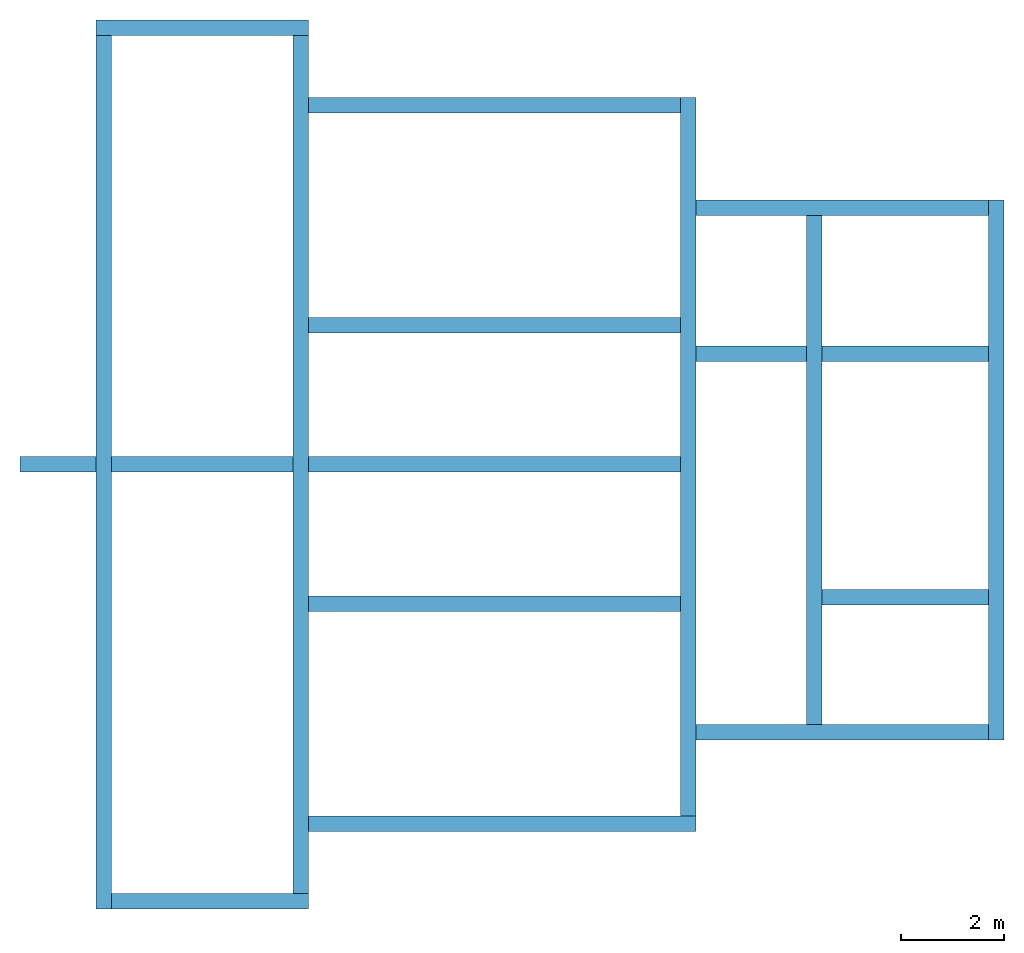
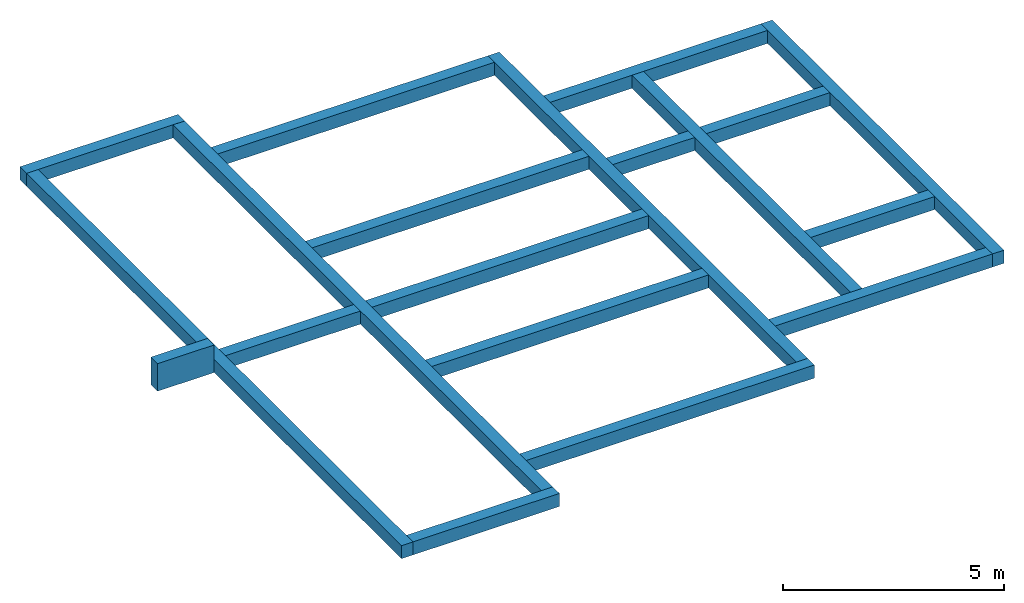
# One storey: 16 walls.
"""IFC2X3 building model written with IfcOpenShell, lengths in millimetres."""

from ifc_helpers import new_model, entity, si_unit, converted_unit, derived_unit, direction, frame, frame_2d, origin, place, context, subcontext, project, spatial, polyline, rectangle, extrude, clip, bounded_halfspace, material, layer, layer_set, layer_usage, type_object, element, save


model = new_model("IFC2X3")

# Units and contexts
model_context = context("Model", 3, precision=0.01, world=origin(), true_north=direction((6.12303176911189e-17, 1.0)))
body_context = subcontext(model_context, "Body", "Model", "MODEL_VIEW")
ifc_project = project(units=[si_unit("LENGTHUNIT", "METRE", prefix="MILLI"), si_unit("AREAUNIT", "SQUARE_METRE"), si_unit("VOLUMEUNIT", "CUBIC_METRE"), converted_unit("PLANEANGLEUNIT", "DEGREE", entity("IfcRatioMeasure", 0.0174532925199433), si_unit("PLANEANGLEUNIT", "RADIAN"), dimensions=[0, 0, 0, 0, 0, 0, 0]), si_unit("MASSUNIT", "GRAM", prefix="KILO"), derived_unit("MASSDENSITYUNIT", [(si_unit("MASSUNIT", "GRAM", prefix="KILO"), 1), (si_unit("LENGTHUNIT", "METRE"), -3)]), si_unit("TIMEUNIT", "SECOND"), si_unit("FREQUENCYUNIT", "HERTZ"), si_unit("THERMODYNAMICTEMPERATUREUNIT", "DEGREE_CELSIUS"), derived_unit("THERMALTRANSMITTANCEUNIT", [(si_unit("MASSUNIT", "GRAM", prefix="KILO"), 1), (si_unit("THERMODYNAMICTEMPERATUREUNIT", "KELVIN"), -1), (si_unit("TIMEUNIT", "SECOND"), -3)]), derived_unit("VOLUMETRICFLOWRATEUNIT", [(si_unit("LENGTHUNIT", "METRE"), 3), (si_unit("TIMEUNIT", "SECOND"), -1)]), si_unit("ELECTRICCURRENTUNIT", "AMPERE"), si_unit("ELECTRICVOLTAGEUNIT", "VOLT"), si_unit("POWERUNIT", "WATT"), si_unit("FORCEUNIT", "NEWTON", prefix="KILO"), si_unit("ILLUMINANCEUNIT", "LUX"), si_unit("LUMINOUSFLUXUNIT", "LUMEN"), si_unit("LUMINOUSINTENSITYUNIT", "CANDELA"), derived_unit("USERDEFINED", [(si_unit("MASSUNIT", "GRAM", prefix="KILO"), -1), (si_unit("LENGTHUNIT", "METRE"), -2), (si_unit("TIMEUNIT", "SECOND"), 3), (si_unit("LUMINOUSFLUXUNIT", "LUMEN"), 1)]), derived_unit("LINEARVELOCITYUNIT", [(si_unit("LENGTHUNIT", "METRE"), 1), (si_unit("TIMEUNIT", "SECOND"), -1)]), si_unit("PRESSUREUNIT", "PASCAL"), derived_unit("USERDEFINED", [(si_unit("LENGTHUNIT", "METRE"), -2), (si_unit("MASSUNIT", "GRAM", prefix="KILO"), 1), (si_unit("TIMEUNIT", "SECOND"), -2)])], contexts=[model_context])

# Site, building, storey
site_placement = place(None, origin())
site = spatial("IfcSite", under=ifc_project, at=site_placement, CompositionType="ELEMENT")
building_placement = place(site_placement, origin())
building = spatial("IfcBuilding", under=site, at=building_placement, CompositionType="ELEMENT")
storey_placement = place(building_placement, frame((0.0, 0.0, -900.0)))
storey = spatial("IfcBuildingStorey", under=building, at=storey_placement, Name="A1 Top of Foundation", CompositionType="ELEMENT", Elevation=-900.0)

# Walls
ifc_material = material(Name="02_C40/50")
ifc_layer = layer(ifc_material, 300.0)
ifc_layer_set = layer_set([ifc_layer], Name="Basic Wall:300mm Beton")
ifc_layer_usage_1 = layer_usage(ifc_layer_set, "AXIS2", "NEGATIVE", 150.0)
wall_type = type_object("IfcWallType", Name="Basic Wall:300mm Beton", PredefinedType="STANDARD", material=ifc_layer_set)
wall_1_placement = place(storey_placement, frame((21293.4900708518, -60361.2395851399, 0.0), z_axis=(0.0, 0.0, 1.0), x_axis=(-1.0, 0.0, 0.0)))
element("IfcWallStandardCase", 1, at=wall_1_placement, inside=storey, type_object=wall_type, material=ifc_layer_usage_1, Name="Basic Wall:300mm Beton", ObjectType="Basic Wall:300mm Beton", context=body_context, shape_type="Clipping", body=[
    clip(extrude(rectangle(XDim=4120.00000000004, YDim=300.000000000001, at=frame_2d((2060.00000000002, 2.70006239588838e-13), x_axis=(-1.0, 0.0))), origin(), (0.0, 0.0, 1.0), 360.0), bounded_halfspace(frame((0.0, -150.0, 360.0), z_axis=(0.0, 0.0, -1.0), x_axis=(-1.0, 0.0, 0.0)), True, frame((0.0, -150.0, 360.0), z_axis=(0.0, 0.0, -1.0), x_axis=(-1.0, 0.0, 0.0)), polyline([(0.0, 0.0), (0.0, 300.0), (-300.0, 300.0), (-3820.0, 300.0), (-4120.0, 300.0), (-4120.0, 0.0), (0.0, 0.0)]))),
])
ifc_layer_usage_2 = layer_usage(ifc_layer_set, "AXIS2", "NEGATIVE", 150.0)
wall_2_placement = place(storey_placement, frame((17323.4900708518, -60511.2395851399, 0.0), z_axis=(0.0, 0.0, 1.0), x_axis=(0.0, -1.0, 0.0)))
element("IfcWallStandardCase", 2, at=wall_2_placement, inside=storey, type_object=wall_type, material=ifc_layer_usage_2, Name="Basic Wall:300mm Beton", ObjectType="Basic Wall:300mm Beton", context=body_context, shape_type="Clipping", body=[
    clip(extrude(rectangle(XDim=16940.0, YDim=300.000000000001, at=frame_2d((8469.99999999999, -4.2632564145606e-14), x_axis=(-1.0, 0.0))), origin(), (0.0, 0.0, 1.0), 360.0), bounded_halfspace(frame((0.0, -150.0, 360.0), z_axis=(0.0, 0.0, -1.0), x_axis=(0.0, 1.0, 0.0)), True, frame((0.0, -150.0, 360.0), z_axis=(0.0, 0.0, -1.0), x_axis=(0.0, 1.0, 0.0)), polyline([(0.0, 0.0), (300.0, 0.0), (300.0, 8170.0), (300.0, 8470.0), (300.0, 16640.0), (300.0, 16940.0), (0.0, 16940.0), (0.0, 0.0)]))),
])
ifc_layer_usage_3 = layer_usage(ifc_layer_set, "AXIS2", "NEGATIVE", 150.0)
wall_3_placement = place(storey_placement, frame((17473.4900708518, -77301.2395851399, 0.0)))
element("IfcWallStandardCase", 3, at=wall_3_placement, inside=storey, type_object=wall_type, material=ifc_layer_usage_3, Name="Basic Wall:300mm Beton", ObjectType="Basic Wall:300mm Beton", context=body_context, shape_type="Clipping", body=[
    clip(extrude(rectangle(XDim=3820.00000000002, YDim=300.000000000001, at=frame_2d((1910.00000000001, -5.6843418860808e-14), x_axis=(-1.0, 0.0))), origin(), (0.0, 0.0, 1.0), 360.0), bounded_halfspace(frame((0.0, -150.0, 360.0), z_axis=(0.0, 0.0, -1.0), x_axis=(1.0, 0.0, 0.0)), True, frame((0.0, -150.0, 360.0), z_axis=(0.0, 0.0, -1.0), x_axis=(1.0, 0.0, 0.0)), polyline([(0.0, 0.0), (0.0, -300.0), (3520.0, -300.0), (3820.0, -300.0), (3820.0, 0.0), (0.0, 0.0)]))),
])
ifc_layer_usage_4 = layer_usage(ifc_layer_set, "AXIS2", "NEGATIVE", 150.0)
wall_4_placement = place(storey_placement, frame((21143.4900708518, -77151.2395851399, 0.0), z_axis=(0.0, 0.0, 1.0), x_axis=(0.0, 1.0, 0.0)))
element("IfcWallStandardCase", 4, at=wall_4_placement, inside=storey, type_object=wall_type, material=ifc_layer_usage_4, Name="Basic Wall:300mm Beton", ObjectType="Basic Wall:300mm Beton", context=body_context, shape_type="Clipping", body=[
    clip(extrude(rectangle(XDim=16640.0, YDim=300.000000000001, at=frame_2d((8319.99999999999, -7.105427357601e-13), x_axis=(-1.0, 0.0))), origin(), (0.0, 0.0, 1.0), 360.0), bounded_halfspace(frame((15440.0, -150.0, 360.0), z_axis=(0.0, 0.0, -1.0), x_axis=(0.0, -1.0, 0.0)), True, frame((15440.0, -150.0, 360.0), z_axis=(0.0, 0.0, -1.0), x_axis=(0.0, -1.0, 0.0)), polyline([(0.0, 0.0), (0.0, 300.0), (0.0, 4270.0), (0.0, 4570.0), (0.0, 6970.0), (0.0, 7270.0), (0.0, 9670.0), (0.0, 9970.0), (0.0, 13940.0), (0.0, 14240.0), (0.0, 15440.0), (-300.0, 15440.0), (-300.0, 7270.0), (-300.0, 6970.0), (-300.0, -1200.0), (0.0, -1200.0), (0.0, 0.0)]))),
])
ifc_layer_usage_5 = layer_usage(ifc_layer_set, "AXIS2", "NEGATIVE", 150.0)
wall_5_placement = place(storey_placement, frame((21293.4900708518, -75801.2395851399, 0.0)))
element("IfcWallStandardCase", 5, at=wall_5_placement, inside=storey, type_object=wall_type, material=ifc_layer_usage_5, Name="Basic Wall:300mm Beton", ObjectType="Basic Wall:300mm Beton", context=body_context, shape_type="Clipping", body=[
    clip(extrude(rectangle(XDim=7519.99999999999, YDim=300.000000000001, at=frame_2d((3759.99999999999, -9.9475983006414e-14), x_axis=(-1.0, 0.0))), origin(), (0.0, 0.0, 1.0), 360.0), bounded_halfspace(frame((0.0, -150.0, 360.0), z_axis=(0.0, 0.0, -1.0), x_axis=(1.0, 0.0, 0.0)), True, frame((0.0, -150.0, 360.0), z_axis=(0.0, 0.0, -1.0), x_axis=(1.0, 0.0, 0.0)), polyline([(0.0, 0.0), (0.0, -300.0), (7220.0, -300.0), (7520.0, -300.0), (7520.0, 0.0), (0.0, 0.0)]))),
])
ifc_layer_usage_6 = layer_usage(ifc_layer_set, "AXIS2", "NEGATIVE", 150.0)
wall_6_placement = place(storey_placement, frame((28663.4900708518, -75651.2395851399, 0.0), z_axis=(0.0, 0.0, 1.0), x_axis=(0.0, 1.0, 0.0)))
element("IfcWallStandardCase", 6, at=wall_6_placement, inside=storey, type_object=wall_type, material=ifc_layer_usage_6, Name="Basic Wall:300mm Beton", ObjectType="Basic Wall:300mm Beton", context=body_context, shape_type="Clipping", body=[
    clip(extrude(rectangle(XDim=13940.0, YDim=300.000000000001, at=frame_2d((6969.99999999999, 0.0), x_axis=(-1.0, 0.0))), origin(), (0.0, 0.0, 1.0), 360.0), bounded_halfspace(frame((0.0, -150.0, 360.0), z_axis=(0.0, 0.0, -1.0), x_axis=(0.0, -1.0, 0.0)), True, frame((0.0, -150.0, 360.0), z_axis=(0.0, 0.0, -1.0), x_axis=(0.0, -1.0, 0.0)), polyline([(0.0, 0.0), (-300.0, 0.0), (-300.0, -3970.0), (-300.0, -4270.0), (-300.0, -6670.0), (-300.0, -6970.0), (-300.0, -9370.0), (-300.0, -9670.0), (-300.0, -13640.0), (-300.0, -13940.0), (0.0, -13940.0), (0.0, -11945.4153945436), (0.0, -11645.4153945436), (0.0, -9115.41539454359), (0.0, -8815.41539454359), (0.0, 0.0)]))),
])
wall_7_placement = place(storey_placement, frame((28513.4900708518, -68831.2395851399, 0.0), z_axis=(0.0, 0.0, 1.0), x_axis=(-1.0, 0.0, 0.0)))
element("IfcWall", 7, at=wall_7_placement, inside=storey, type_object=wall_type, Name="Basic Wall:300mm Beton", ObjectType="Basic Wall:300mm Beton", context=body_context, shape_type="SweptSolid", body=[
    extrude(rectangle(XDim=7219.99999999998, YDim=300.000000000001, at=frame_2d((0.0, -4.33431068813661e-12), x_axis=(1.0, 0.0))), frame((3610.0, 0.0, 0.0)), (0.0, 0.0, 1.0), 360.0),
    extrude(rectangle(XDim=300.000000000001, YDim=1474.99999999999, at=frame_2d((-4.33431068813661e-12, -1.08002495835535e-12), x_axis=(1.0, 0.0))), frame((12077.5, 0.0, 0.0), z_axis=(0.0, 0.0, 1.0), x_axis=(0.0, 1.0, 0.0)), (0.0, 0.0, 1.0), 760.0),
    extrude(rectangle(XDim=3520.00000000004, YDim=300.000000000001, at=frame_2d((0.0, 4.33431068813661e-12), x_axis=(1.0, 0.0))), frame((9280.0, 0.0, 0.0), z_axis=(0.0, 0.0, 1.0), x_axis=(-1.0, 0.0, 0.0)), (0.0, 0.0, 1.0), 360.0),
])
ifc_layer_usage_7 = layer_usage(ifc_layer_set, "AXIS2", "POSITIVE", -150.0)
wall_8_placement = place(storey_placement, frame((21293.4900708518, -61861.2395851399, 0.0)))
element("IfcWallStandardCase", 8, at=wall_8_placement, inside=storey, type_object=wall_type, material=ifc_layer_usage_7, Name="Basic Wall:300mm Beton", ObjectType="Basic Wall:300mm Beton", context=body_context, shape_type="Clipping", body=[
    clip(extrude(rectangle(XDim=7219.99999999997, YDim=300.000000000001, at=frame_2d((3609.99999999999, -1.4210854715202e-12), x_axis=(-1.0, 0.0))), origin(), (0.0, 0.0, 1.0), 360.0), bounded_halfspace(frame((0.0, -150.0, 360.0), z_axis=(0.0, 0.0, -1.0), x_axis=(1.0, 0.0, 0.0)), True, frame((0.0, -150.0, 360.0), z_axis=(0.0, 0.0, -1.0), x_axis=(1.0, 0.0, 0.0)), polyline([(0.0, 0.0), (0.0, -300.0), (7220.0, -300.0), (7220.0, 0.0), (0.0, 0.0)]))),
])
ifc_layer_usage_8 = layer_usage(ifc_layer_set, "AXIS2", "NEGATIVE", 150.0)
wall_9_placement = place(storey_placement, frame((31103.4900708518, -73875.8241905963, 0.0), z_axis=(0.0, 0.0, 1.0), x_axis=(0.0, 1.0, 0.0)))
element("IfcWallStandardCase", 9, at=wall_9_placement, inside=storey, type_object=wall_type, material=ifc_layer_usage_8, Name="Basic Wall:300mm Beton", ObjectType="Basic Wall:300mm Beton", context=body_context, shape_type="Clipping", body=[
    clip(extrude(rectangle(XDim=9869.99999999997, YDim=300.000000000001, at=frame_2d((4934.99999999999, 1.17950094136177e-12), x_axis=(-1.0, 0.0))), origin(), (0.0, 0.0, 1.0), 360.0), bounded_halfspace(frame((0.0, -150.0, 360.0), z_axis=(0.0, 0.0, -1.0), x_axis=(-1.0, 0.0, 0.0)), True, frame((0.0, -150.0, 360.0), z_axis=(0.0, 0.0, -1.0), x_axis=(-1.0, 0.0, 0.0)), polyline([(0.0, 0.0), (0.0, 300.0), (-7040.0, 300.0), (-7340.0, 300.0), (-9870.0, 300.0), (-9870.0, 0.0), (-7340.0, 0.0), (-7040.0, 0.0), (-2615.0, 0.0), (-2315.0, 0.0), (0.0, 0.0)]))),
])
ifc_layer_usage_9 = layer_usage(ifc_layer_set, "AXIS2", "NEGATIVE", 150.0)
wall_10_placement = place(storey_placement, frame((34633.4900708517, -74175.8241905963, 0.0), z_axis=(0.0, 0.0, 1.0), x_axis=(0.0, 1.0, 0.0)))
element("IfcWallStandardCase", 10, at=wall_10_placement, inside=storey, type_object=wall_type, material=ifc_layer_usage_9, Name="Basic Wall:300mm Beton", ObjectType="Basic Wall:300mm Beton", context=body_context, shape_type="Clipping", body=[
    clip(extrude(rectangle(XDim=10470.0, YDim=300.000000000001, at=frame_2d((5234.99999999999, 1.63424829224823e-12), x_axis=(-1.0, 0.0))), origin(), (0.0, 0.0, 1.0), 360.0), bounded_halfspace(frame((0.0, -150.0, 360.0), z_axis=(0.0, 0.0, -1.0), x_axis=(-1.0, 0.0, 0.0)), True, frame((0.0, -150.0, 360.0), z_axis=(0.0, 0.0, -1.0), x_axis=(-1.0, 0.0, 0.0)), polyline([(0.0, 0.0), (0.0, 300.0), (-10170.0, 300.0), (-10470.0, 300.0), (-10470.0, 0.0), (0.0, 0.0)]))),
])
ifc_layer_usage_10 = layer_usage(ifc_layer_set, "AXIS2", "POSITIVE", -150.0)
wall_11_placement = place(storey_placement, frame((28813.4900708518, -63855.8241905963, 0.0)))
element("IfcWallStandardCase", 11, at=wall_11_placement, inside=storey, type_object=wall_type, material=ifc_layer_usage_10, Name="Basic Wall:300mm Beton", ObjectType="Basic Wall:300mm Beton", context=body_context, shape_type="Clipping", body=[
    clip(extrude(rectangle(XDim=5669.99999999996, YDim=300.000000000001, at=frame_2d((2834.99999999998, 4.2632564145606e-13), x_axis=(-1.0, 0.0))), origin(), (0.0, 0.0, 1.0), 360.0), bounded_halfspace(frame((0.0, -150.0, 360.0), z_axis=(0.0, 0.0, -1.0), x_axis=(0.0, -1.0, 0.0)), True, frame((0.0, -150.0, 360.0), z_axis=(0.0, 0.0, -1.0), x_axis=(0.0, -1.0, 0.0)), polyline([(0.0, 0.0), (-300.0, 0.0), (-300.0, -5670.0), (0.0, -5670.0), (0.0, -2440.0), (0.0, -2140.0), (0.0, 0.0)]))),
])
wall_12_placement = place(storey_placement, frame((28813.4900708518, -66685.8241905963, 0.0)))
element("IfcWall", 12, at=wall_12_placement, inside=storey, type_object=wall_type, Name="Basic Wall:300mm Beton", ObjectType="Basic Wall:300mm Beton", context=body_context, shape_type="SweptSolid", body=[
    extrude(rectangle(XDim=2140.0, YDim=300.000000000001, at=frame_2d((-2.1600499167107e-12, -4.33431068813661e-12), x_axis=(1.0, 0.0))), frame((1070.0, 0.0, 0.0), z_axis=(0.0, 0.0, 1.0), x_axis=(-1.0, 0.0, 0.0)), (0.0, 0.0, 1.0), 360.0),
    extrude(rectangle(XDim=3229.99999999996, YDim=300.000000000001, at=frame_2d((0.0, -4.33431068813661e-12), x_axis=(1.0, 0.0))), frame((4055.0, 0.0, 0.0)), (0.0, 0.0, 1.0), 360.0),
])
ifc_layer_usage_11 = layer_usage(ifc_layer_set, "AXIS2", "NEGATIVE", 150.0)
wall_13_placement = place(storey_placement, frame((28813.4900708518, -74025.8241905963, 0.0)))
element("IfcWallStandardCase", 13, at=wall_13_placement, inside=storey, type_object=wall_type, material=ifc_layer_usage_11, Name="Basic Wall:300mm Beton", ObjectType="Basic Wall:300mm Beton", context=body_context, shape_type="Clipping", body=[
    clip(extrude(rectangle(XDim=5669.99999999996, YDim=300.000000000001, at=frame_2d((2834.99999999998, -3.08375547319883e-12), x_axis=(-1.0, 0.0))), origin(), (0.0, 0.0, 1.0), 360.0), bounded_halfspace(frame((0.0, -150.0, 360.0), z_axis=(0.0, 0.0, -1.0), x_axis=(0.0, -1.0, 0.0)), True, frame((0.0, -150.0, 360.0), z_axis=(0.0, 0.0, -1.0), x_axis=(0.0, -1.0, 0.0)), polyline([(0.0, 0.0), (-300.0, 0.0), (-300.0, -2140.0), (-300.0, -2440.0), (-300.0, -5670.0), (0.0, -5670.0), (0.0, 0.0)]))),
])
ifc_layer_usage_12 = layer_usage(ifc_layer_set, "AXIS2", "POSITIVE", -150.0)
wall_14_placement = place(storey_placement, frame((31253.4900708518, -71410.8241905963, 0.0)))
element("IfcWallStandardCase", 14, at=wall_14_placement, inside=storey, type_object=wall_type, material=ifc_layer_usage_12, Name="Basic Wall:300mm Beton", ObjectType="Basic Wall:300mm Beton", context=body_context, shape_type="Clipping", body=[
    clip(extrude(rectangle(XDim=3229.99999999996, YDim=300.000000000001, at=frame_2d((1614.99999999998, 8.5265128291212e-13), x_axis=(-1.0, 0.0))), origin(), (0.0, 0.0, 1.0), 360.0), bounded_halfspace(frame((0.0, -150.0, 360.0), z_axis=(0.0, 0.0, -1.0), x_axis=(0.0, -1.0, 0.0)), True, frame((0.0, -150.0, 360.0), z_axis=(0.0, 0.0, -1.0), x_axis=(0.0, -1.0, 0.0)), polyline([(0.0, 0.0), (-300.0, 0.0), (-300.0, -3230.0), (0.0, -3230.0), (0.0, 0.0)]))),
])
ifc_layer_usage_13 = layer_usage(ifc_layer_set, "AXIS2", "NEGATIVE", 150.0)
wall_15_placement = place(storey_placement, frame((28513.4900708518, -71531.2395851399, 0.0), z_axis=(0.0, 0.0, 1.0), x_axis=(-1.0, 0.0, 0.0)))
element("IfcWallStandardCase", 15, at=wall_15_placement, inside=storey, type_object=wall_type, material=ifc_layer_usage_13, Name="Basic Wall:300mm Beton", ObjectType="Basic Wall:300mm Beton", context=body_context, shape_type="Clipping", body=[
    clip(extrude(rectangle(XDim=7219.99999999998, YDim=300.000000000001, at=frame_2d((3609.99999999999, -9.66338120633736e-13), x_axis=(-1.0, 0.0))), origin(), (0.0, 0.0, 1.0), 360.0), bounded_halfspace(frame((0.0, -150.0, 360.0), z_axis=(0.0, 0.0, -1.0), x_axis=(-1.0, 0.0, 0.0)), True, frame((0.0, -150.0, 360.0), z_axis=(0.0, 0.0, -1.0), x_axis=(-1.0, 0.0, 0.0)), polyline([(0.0, 0.0), (0.0, 300.0), (-7220.0, 300.0), (-7220.0, 0.0), (0.0, 0.0)]))),
])
ifc_layer_usage_14 = layer_usage(ifc_layer_set, "AXIS2", "POSITIVE", -150.0)
wall_16_placement = place(storey_placement, frame((28513.4900708518, -66131.2395851399, 0.0), z_axis=(0.0, 0.0, 1.0), x_axis=(-1.0, 0.0, 0.0)))
element("IfcWallStandardCase", 16, at=wall_16_placement, inside=storey, type_object=wall_type, material=ifc_layer_usage_14, Name="Basic Wall:300mm Beton", ObjectType="Basic Wall:300mm Beton", context=body_context, shape_type="Clipping", body=[
    clip(extrude(rectangle(XDim=7219.99999999998, YDim=300.000000000001, at=frame_2d((3609.99999999999, -8.38440428196918e-13), x_axis=(-1.0, 0.0))), origin(), (0.0, 0.0, 1.0), 360.0), bounded_halfspace(frame((0.0, -150.0, 360.0), z_axis=(0.0, 0.0, -1.0), x_axis=(-1.0, 0.0, 0.0)), True, frame((0.0, -150.0, 360.0), z_axis=(0.0, 0.0, -1.0), x_axis=(-1.0, 0.0, 0.0)), polyline([(0.0, 0.0), (0.0, 300.0), (-7220.0, 300.0), (-7220.0, 0.0), (0.0, 0.0)]))),
])

save(model, "model.ifc")
